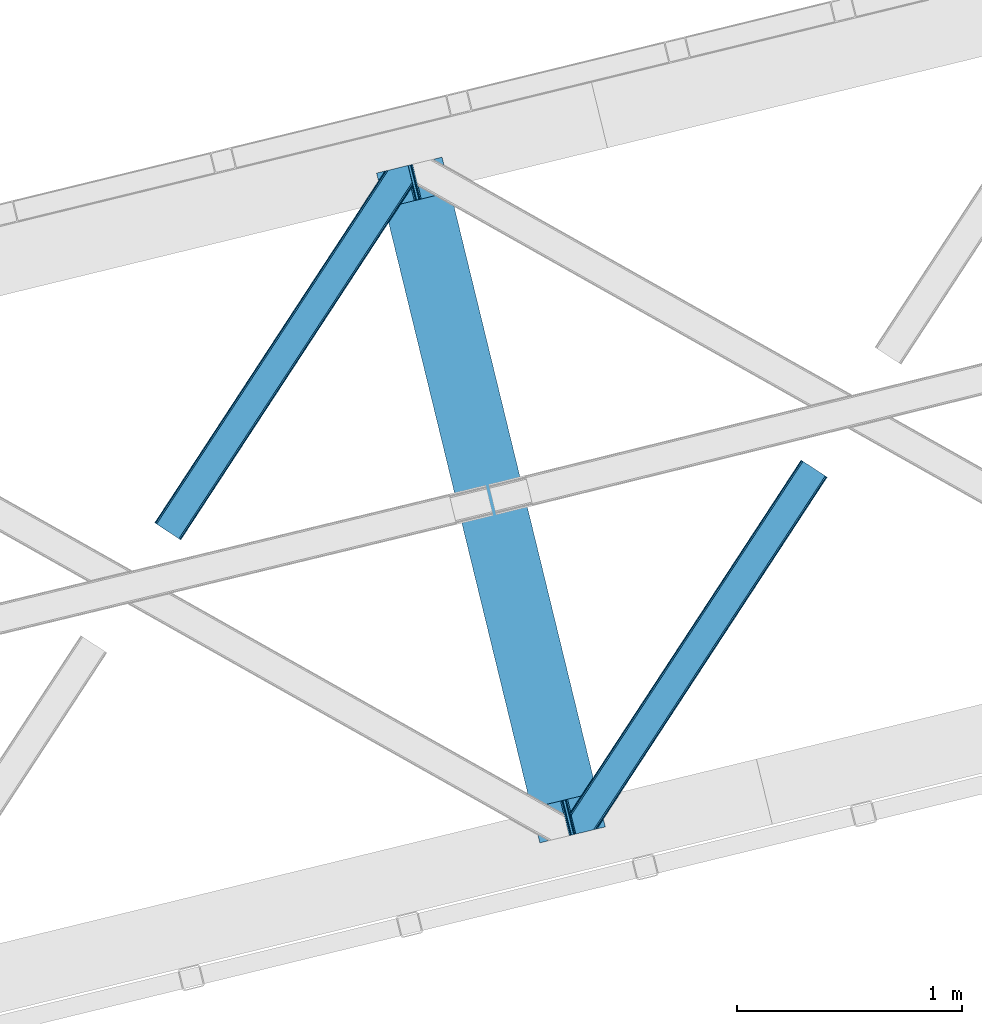
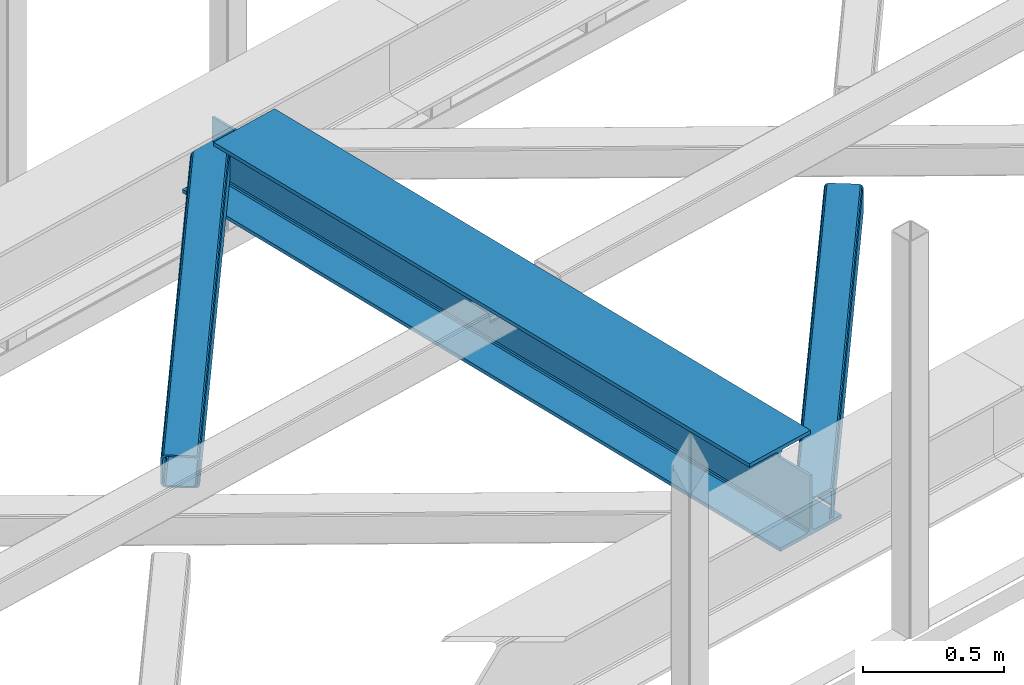
# One storey, part 29 of 66: 2 members, 1 beam.
"""IFC4 building model written with IfcOpenShell, lengths in millimetres."""

from ifc_helpers import new_model, entity, si_unit, converted_unit, derived_unit, direction, frame, origin, place, context, subcontext, project, spatial, triangles, polygons, material, type_object, element, save


model = new_model("IFC4")

# Units and contexts
model_context = context("Model", 3, precision=0.01, world=origin(), true_north=direction((6.12303176911189e-17, 1.0)))
plan_context = context("Plan", 3, precision=0.01, world=origin(), true_north=direction((6.12303176911189e-17, 1.0)))
body_context = subcontext(model_context, "Body", "Model", "MODEL_VIEW")
ifc_project = project(units=[si_unit("LENGTHUNIT", "METRE", prefix="MILLI"), si_unit("AREAUNIT", "SQUARE_METRE"), si_unit("VOLUMEUNIT", "CUBIC_METRE"), converted_unit("PLANEANGLEUNIT", "DEGREE", entity("IfcRatioMeasure", 0.0174532925199433), si_unit("PLANEANGLEUNIT", "RADIAN"), dimensions=[0, 0, 0, 0, 0, 0, 0]), si_unit("MASSUNIT", "GRAM", prefix="KILO"), derived_unit("MASSDENSITYUNIT", [(si_unit("MASSUNIT", "GRAM", prefix="KILO"), 1), (si_unit("LENGTHUNIT", "METRE"), -3)]), derived_unit("MOMENTOFINERTIAUNIT", [(si_unit("LENGTHUNIT", "METRE"), 4)]), si_unit("TIMEUNIT", "SECOND"), si_unit("FREQUENCYUNIT", "HERTZ"), si_unit("THERMODYNAMICTEMPERATUREUNIT", "DEGREE_CELSIUS"), derived_unit("THERMALTRANSMITTANCEUNIT", [(si_unit("MASSUNIT", "GRAM", prefix="KILO"), 1), (si_unit("THERMODYNAMICTEMPERATUREUNIT", "KELVIN"), -1), (si_unit("TIMEUNIT", "SECOND"), -3)]), derived_unit("VOLUMETRICFLOWRATEUNIT", [(si_unit("LENGTHUNIT", "METRE"), 3), (si_unit("TIMEUNIT", "SECOND"), -1)]), derived_unit("MASSFLOWRATEUNIT", [(si_unit("MASSUNIT", "GRAM", prefix="KILO"), 1), (si_unit("TIMEUNIT", "SECOND"), -1)]), derived_unit("ROTATIONALFREQUENCYUNIT", [(si_unit("TIMEUNIT", "SECOND"), -1)]), si_unit("ELECTRICCURRENTUNIT", "AMPERE"), si_unit("ELECTRICVOLTAGEUNIT", "VOLT"), si_unit("POWERUNIT", "WATT"), si_unit("FORCEUNIT", "NEWTON", prefix="KILO"), si_unit("ILLUMINANCEUNIT", "LUX"), si_unit("LUMINOUSFLUXUNIT", "LUMEN"), si_unit("LUMINOUSINTENSITYUNIT", "CANDELA"), derived_unit("USERDEFINED", [(si_unit("MASSUNIT", "GRAM", prefix="KILO"), -1), (si_unit("LENGTHUNIT", "METRE"), -2), (si_unit("TIMEUNIT", "SECOND"), 3), (si_unit("LUMINOUSFLUXUNIT", "LUMEN"), 1)]), derived_unit("LINEARVELOCITYUNIT", [(si_unit("LENGTHUNIT", "METRE"), 1), (si_unit("TIMEUNIT", "SECOND"), -1)]), si_unit("PRESSUREUNIT", "PASCAL"), derived_unit("USERDEFINED", [(si_unit("LENGTHUNIT", "METRE"), -2), (si_unit("MASSUNIT", "GRAM", prefix="KILO"), 1), (si_unit("TIMEUNIT", "SECOND"), -2)]), derived_unit("LINEARFORCEUNIT", [(si_unit("MASSUNIT", "GRAM", prefix="KILO"), 1), (si_unit("LENGTHUNIT", "METRE"), 1), (si_unit("TIMEUNIT", "SECOND"), -2), (si_unit("LENGTHUNIT", "METRE"), -1)]), derived_unit("PLANARFORCEUNIT", [(si_unit("MASSUNIT", "GRAM", prefix="KILO"), 1), (si_unit("LENGTHUNIT", "METRE"), 1), (si_unit("TIMEUNIT", "SECOND"), -2), (si_unit("LENGTHUNIT", "METRE"), -2)])], contexts=[model_context, plan_context])

# Site, building, storey
site_placement = place(None, origin())
site = spatial("IfcSite", under=ifc_project, at=site_placement, CompositionType="ELEMENT")
building_placement = place(site_placement, origin())
building = spatial("IfcBuilding", under=site, at=building_placement, CompositionType="ELEMENT")
storey_placement = place(building_placement, frame((0.0, 0.0, 19800.0)))
storey = spatial("IfcBuildingStorey", under=building, at=storey_placement, Name="06", CompositionType="ELEMENT", Elevation=19800.0)

# Beam
ifc_material = material(Name="Metal painted (White)")
beam_type = type_object("IfcBeamType", PredefinedType="BEAM")
beam_placement = place(storey_placement, frame((-43080.93, 7293.5, 3808.0)))
element("IfcBeam", 1, at=beam_placement, inside=storey, type_object=beam_type, material=ifc_material, ObjectType="Steel Beam", PredefinedType="BEAM", context=body_context, shape_type="Tessellation", body=[
    polygons([(1018.1664837833, 71.047827897101, 15.5000000000051), (1018.1664837833, 71.0478278971021, 0.0), (291.465617442446, 3052.25531830421, 0.0), (291.465617442455, 3052.25531830421, 15.5000000000051), (894.779372399338, 40.9709140873291, 15.5000000000051), (168.078506058482, 3022.17840449444, 15.5000000000051), (888.087028625366, 39.3395844888243, 16.8701684148028), (161.38616228452, 3020.54707489594, 16.8701684148028), (882.413533524751, 37.956610033653, 20.7720779386478), (155.712667183904, 3019.16410044076, 20.7720779386478), (878.622625296176, 37.0325360459184, 26.6116982174338), (151.921758955329, 3018.24002645303, 26.6116982174338), (877.291435352788, 36.7080444135018, 33.500000000001), (150.590569011924, 3017.91553482062, 33.500000000001), (140.875048430514, 3015.54727389071, 33.500000000001), (140.875048430522, 3015.54727389071, 259.000000000006), (150.590569011924, 3017.91553482061, 259.000000000006), (0.0, 2981.20749040711, 4.33146851719357e-12), (0.0, 2981.20749040711, 15.5000000000051), (123.387111383972, 3011.28440421688, 15.5000000000051), (130.079455157918, 3012.91573381539, 16.8701684148028), (135.752950258542, 3014.29870827056, 20.7720779386478), (139.543858487117, 3015.2227822583, 26.6116982174338), (877.291435352779, 36.7080444135018, 259.000000000006), (867.575914771369, 34.3397834835981, 259.000000000006), (867.575914771369, 34.3397834835981, 33.500000000001), (866.244724827972, 34.0152918511837, 26.6116982174338), (862.453816599406, 33.0912178634492, 20.7720779386478), (856.780321498782, 31.7082434082778, 16.8701684148028), (850.087977724819, 30.076913809773, 15.5000000000051), (726.700866340864, 0.0, 15.5000000000051), (726.700866340864, 0.0, 4.33146851719357e-12), (839.723099725414, 190.827961666225, 259.069792599954), (188.068298227647, 2864.16742161973, 259.000000000006), (188.291691329497, 2863.25097721476, 259.617303331129), (188.304080173122, 2863.20015298098, 266.500003008253), (839.577920935824, 191.42343960925, 266.500002998871), (839.578271056576, 191.422003304514, 260.000004007593), (830.098162489501, 188.087889491627, 259.00634317046), (829.874792453805, 189.004341089457, 259.617303331129), (829.862403610162, 189.055165323231, 266.500003008253), (178.588562847469, 2860.83187869496, 266.500002998871), (178.588212726717, 2860.8333149997, 260.000004007593), (178.443407068381, 2861.42736381349, 259.076120467494), (178.352777646246, 2861.79916068982, 259.000000000006), (840.90940880576, 191.746709053936, 273.388305639792), (844.699685394447, 192.673374225849, 279.227924098781), (850.372756341985, 194.058088689525, 283.129832400619), (857.06494802311, 195.690042220338, 284.500000377228), (980.451976710954, 225.76729527545, 284.500000138975), (980.450306904303, 225.774145344181, 299.999995328161), (688.984884807032, 154.725516080139, 299.999995890966), (688.986554613693, 154.718666011408, 284.500000701776), (812.373583301528, 184.795919066518, 284.500000463524), (819.066070197675, 186.426661533098, 283.129832461069), (824.739981846427, 187.807927177623, 279.227924137327), (828.531516633419, 188.72943082692, 273.388305663689), (177.257074977551, 2860.50860925028, 273.388305639792), (173.466798388846, 2859.58194407836, 279.227924098781), (167.793727441316, 2858.19722961469, 283.129832400619), (161.101535760182, 2856.56527608387, 284.500000377228), (37.7145070723471, 2826.48802302876, 284.500000138975), (37.7161768789988, 2826.48117296003, 299.999995328161), (329.181598976269, 2897.52980222407, 299.999995890962), (329.179929169617, 2897.5366522928, 284.500000701776), (205.792900481765, 2867.45939923769, 284.500000463524), (199.100413585626, 2865.82865677111, 283.129832461069), (193.426501936866, 2864.44739112659, 279.227924137327), (189.634967149874, 2863.52588747729, 273.388305663689)], [[[1, 2, 3, 4]], [[5, 1, 4, 6]], [[7, 5, 6, 8]], [[9, 7, 8, 10]], [[11, 9, 10, 12]], [[13, 11, 12, 14]], [[15, 16, 17, 14, 12, 10, 8, 6, 4, 3, 18, 19, 20, 21, 22, 23]], [[13, 24, 25, 26, 27, 28, 29, 30, 31, 32, 2, 1, 5, 7, 9, 11]], [[2, 32, 18, 3]], [[32, 31, 19, 18]], [[31, 30, 20, 19]], [[27, 26, 15, 23]], [[28, 27, 23, 22]], [[29, 28, 22, 21]], [[30, 29, 21, 20]], [[33, 24, 13, 14, 17, 34, 35, 36, 37, 38]], [[25, 39, 40, 41, 42, 43, 44, 16, 15, 26]], [[39, 25, 24, 33]], [[45, 34, 17, 16]], [[41, 40, 38, 37, 46, 47, 48, 49, 50, 51, 52, 53, 54, 55, 56, 57]], [[42, 58, 59, 60, 61, 62, 63, 64, 65, 66, 67, 68, 69, 36, 35, 43]], [[46, 37, 36, 69]], [[47, 46, 69, 68]], [[48, 47, 68, 67]], [[49, 48, 67, 66]], [[50, 49, 66, 65]], [[51, 50, 65, 64]], [[52, 51, 64, 63]], [[53, 52, 63, 62]], [[54, 53, 62, 61]], [[55, 54, 61, 60]], [[56, 55, 60, 59]], [[57, 56, 59, 58]], [[41, 57, 58, 42]]], closed=False),
])

# Members
member_type_1 = type_object("IfcMemberType", PredefinedType="BRACE")
member_1_placement = place(storey_placement, frame((-44069.14, 8641.5, 3824.0)))
element("IfcMember", 2, at=member_1_placement, inside=storey, type_object=member_type_1, ObjectType="Steel Horizontal Brace", PredefinedType="BRACE", context=body_context, shape_type="Tessellation", body=[
    triangles([(994.771838378911, 1564.02662658691, 0.0), (1028.82092285156, 1424.34794311523, 0.0), (14.6409667968765, 67.1040435791019, 0.0), (102.486767578128, 9.58604278564417, 0.0), (1.1162109375, 75.9604797363281, 10.8039916992202), (0.0, 76.6900863647461, 17.5012573242202), (1025.02580566407, 1642.17883300781, 17.5012573242202), (4.28811035156832, 73.8821182250977, 5.12526855468968), (990.474426269531, 1585.8776184082, 9.49942016601563), (990.041894531256, 1584.44747314453, 8.74132690429906), (989.90701904297, 1583.99168701172, 8.49948120117188), (990.758129882815, 1580.48841247559, 5.12526855468968), (1027.30938720703, 1642.73461303711, 10.8691040039084), (1027.77912597657, 1642.84972229004, 9.49942016601563), (992.599877929693, 1572.93538513184, 1.33247680664135), (9.03665771484521, 70.7724243164066, 1.33247680664135), (1025.02580566407, 1642.17883300781, 122.499499511719), (0.0, 76.6900863647461, 122.499499511719), (1026.92336425782, 1642.64043273926, 129.196765136719), (1.1162109375, 75.9604797363281, 129.196765136719), (1032.31838378907, 1643.95546875, 134.87548828125), (4.28811035156832, 73.8821182250977, 134.87548828125), (1040.39230957031, 1645.92395324707, 138.668280029298), (9.03665771484521, 70.7724243164066, 138.668280029298), (1049.91730957032, 1648.24590454102, 140.00075683594), (14.6409667968765, 67.1040435791019, 140.00075683594), (994.869506835938, 1567.85081176758, 9.49942016601563), (994.75788574219, 1567.00667724609, 9.2947814941399), (994.650915527345, 1566.15091552734, 9.08781738281323), (994.539294433598, 1565.30561828613, 8.8831787109375), (994.74393310547, 1564.14522399902, 8.49948120117188), (1047.05236816406, 1647.54827270508, 9.49942016601563), (14.8921142578183, 66.9377746582031, 8.3320495605476), (20.4964233398496, 63.2693939208984, 6.99957275390625), (997.041467285162, 1554.71440429688, 6.99957275390625), (10.1435668945342, 70.0480499267578, 12.1248413085959), (1042.27126464844, 1646.38322753906, 12.1248413085959), (1036.87624511719, 1645.06702880859, 17.8035644531265), (1034.98333740234, 1644.60542907715, 24.5008300781265), (6.97166748047312, 72.1258300781246, 17.8035644531265), (5.85545654297312, 72.8554367065426, 24.5008300781265), (1026.55129394532, 1433.65900268555, 6.99957275390625), (96.6266601562529, 13.4206924438477, 6.99957275390625), (1028.71860351563, 1424.77698669434, 8.41343994140698), (1032.83463134766, 1407.88615722656, 5.12526855468968), (1033.6857421875, 1404.3817199707, 8.49948120117188), (1030.99288330079, 1415.43918457031, 1.33247680664135), (1034.98333740234, 1644.60542907715, 115.499926757813), (5.85545654297312, 72.8554367065426, 115.499926757813), (1050.3498413086, 1648.35171203613, 131.668707275392), (1059.8748413086, 1650.67250061035, 133.001184082033), (20.4964233398496, 63.2693939208984, 133.001184082033), (14.8921142578183, 66.9377746582031, 131.668707275392), (1042.27126464844, 1646.38322753906, 127.873590087893), (10.1435668945342, 70.0480499267578, 127.873590087893), (1036.87624511719, 1645.06702880859, 122.197192382813), (6.97166748047312, 72.1258300781246, 122.197192382813), (1128.10788574219, 1667.30520629883, 140.00075683594), (1128.10788574219, 1667.30520629883, 133.001184082033), (1144.33015136719, 1600.75810546875, 140.00075683594), (102.486767578128, 9.58604278564417, 140.00075683594), (1142.06052246094, 1610.07032775879, 133.001184082033), (96.6266601562529, 13.4206924438477, 133.001184082033), (1146.50211181641, 1591.84934692383, 138.668280029298), (108.08642578125, 5.91766204833948, 138.668280029298), (1148.33920898438, 1584.29631958008, 134.87548828125), (112.834973144534, 2.80738677978479, 134.87548828125), (1149.57169189453, 1579.2501159668, 129.196765136719), (116.011523437504, 0.729606628417969, 129.196765136719), (1150.00422363282, 1577.47813110351, 122.499499511719), (117.127734375004, 0.0, 122.499499511719), (1150.00422363282, 1577.47813110351, 17.5012573242202), (117.127734375004, 0.0, 17.5012573242202), (106.979516601568, 6.64203643798828, 127.873590087893), (110.156066894531, 4.56425628662146, 122.197192382813), (111.267626953129, 3.83406829833984, 115.499926757813), (102.230969238284, 9.75231170654297, 131.668707275392), (116.011523437504, 0.729606628417969, 10.8039916992202), (106.979516601568, 6.64203643798828, 12.1248413085959), (112.834973144534, 2.80738677978479, 5.12526855468968), (111.267626953129, 3.83406829833984, 24.5008300781265), (110.156066894531, 4.56425628662146, 17.8035644531265), (108.08642578125, 5.91766204833948, 1.33247680664135), (102.230969238284, 9.75231170654297, 8.3320495605476), (1147.30206298828, 1588.56233825684, 122.197192382813), (1147.73459472656, 1586.79035339356, 115.499926757813), (1146.06958007813, 1593.60854187012, 127.873590087893), (1144.23248291016, 1601.16040649414, 131.668707275392), (1147.73459472656, 1586.79035339356, 24.5008300781265), (1147.21369628907, 1588.9239440918, 17.8686767578147), (1149.994921875, 1577.51650085449, 16.5013183593765), (1147.10672607422, 1589.36461486816, 16.5013183593765), (1145.27427978516, 1573.10863037109, 10.8714294433594), (1034.62056884766, 1404.788671875, 9.49942016601563), (1144.12551269532, 1572.03427734375, 9.49942016601563), (1142.79071044922, 1588.59721984863, 12.1248413085959), (1030.22548828126, 1422.8143157959, 9.49942016601563), (1029.19764404297, 1423.6724029541, 8.80643920898365), (1139.73043212891, 1590.05992126465, 9.49942016601563)], [[1, 2, 3], [4, 3, 2], [5, 6, 7], [8, 9, 10], [11, 12, 8], [5, 13, 9], [9, 8, 5], [13, 14, 9], [15, 1, 16], [3, 16, 1], [12, 15, 8], [16, 8, 15], [7, 13, 5], [17, 7, 6], [6, 18, 17], [19, 17, 20], [18, 20, 17], [21, 19, 22], [20, 22, 19], [23, 21, 24], [22, 24, 21], [25, 23, 26], [24, 26, 23], [27, 28, 9], [28, 29, 10], [29, 30, 10], [30, 31, 11], [14, 32, 27], [27, 9, 14], [33, 34, 35], [36, 33, 31], [31, 30, 36], [28, 36, 29], [28, 27, 36], [36, 30, 29], [32, 37, 27], [36, 27, 37], [35, 31, 33], [38, 39, 40], [41, 40, 39], [37, 38, 36], [40, 36, 38], [42, 35, 34], [34, 43, 42], [1, 35, 42], [31, 12, 11], [1, 31, 35], [31, 15, 12], [31, 1, 15], [2, 1, 42], [44, 2, 42], [45, 44, 46], [44, 47, 2], [44, 45, 47], [39, 48, 41], [49, 41, 48], [50, 51, 52], [52, 53, 50], [54, 50, 53], [53, 55, 54], [56, 54, 55], [55, 57, 56], [48, 56, 57], [57, 49, 48], [56, 17, 19], [50, 23, 25], [58, 51, 25], [51, 58, 59], [51, 50, 25], [54, 23, 50], [54, 56, 21], [21, 23, 54], [19, 21, 56], [39, 7, 17], [37, 14, 38], [56, 48, 17], [37, 32, 14], [39, 38, 7], [48, 39, 17], [13, 7, 38], [38, 14, 13], [60, 25, 61], [25, 60, 58], [26, 61, 25], [51, 62, 63], [51, 59, 62], [63, 52, 51], [64, 60, 61], [61, 65, 64], [66, 64, 65], [65, 67, 66], [68, 66, 67], [67, 69, 68], [70, 68, 69], [69, 71, 70], [72, 70, 71], [71, 73, 72], [69, 74, 75], [76, 73, 71], [69, 75, 71], [69, 67, 74], [75, 76, 71], [74, 67, 65], [63, 61, 26], [61, 77, 65], [77, 61, 63], [77, 74, 65], [78, 79, 80], [81, 73, 76], [73, 82, 78], [82, 73, 81], [78, 82, 79], [4, 43, 3], [83, 80, 79], [79, 84, 83], [84, 43, 4], [4, 83, 84], [55, 24, 22], [26, 52, 63], [26, 53, 52], [53, 26, 24], [55, 53, 24], [49, 18, 6], [20, 57, 55], [22, 20, 55], [57, 20, 18], [49, 57, 18], [16, 36, 8], [3, 43, 34], [34, 33, 3], [33, 36, 16], [16, 3, 33], [5, 8, 36], [6, 41, 49], [40, 6, 5], [6, 40, 41], [40, 5, 36], [85, 86, 75], [76, 75, 86], [87, 85, 74], [75, 74, 85], [88, 87, 77], [74, 77, 87], [62, 88, 63], [77, 63, 88], [86, 89, 76], [81, 76, 89], [90, 91, 92], [70, 72, 89], [72, 90, 89], [89, 86, 70], [72, 91, 90], [85, 70, 86], [68, 70, 85], [66, 85, 87], [85, 66, 68], [87, 64, 66], [88, 64, 87], [88, 62, 60], [88, 60, 64], [62, 58, 60], [62, 59, 58], [73, 78, 93], [93, 72, 73], [94, 93, 78], [94, 95, 93], [80, 45, 46], [46, 78, 80], [46, 94, 78], [47, 45, 83], [80, 83, 45], [2, 47, 4], [83, 4, 47], [93, 91, 72], [82, 81, 89], [82, 92, 96], [82, 90, 92], [84, 97, 98], [79, 96, 97], [97, 84, 79], [96, 99, 97], [43, 84, 44], [44, 42, 43], [96, 79, 82], [89, 90, 82], [96, 91, 93], [96, 92, 91], [96, 95, 99], [93, 95, 96], [99, 95, 97], [94, 97, 95]]),
])
member_type_2 = type_object("IfcMemberType", PredefinedType="BRACE")
member_2_placement = place(storey_placement, frame((-42217.82, 7332.57, 3824.0)))
element("IfcMember", 3, at=member_2_placement, inside=storey, type_object=member_type_2, ObjectType="Steel Horizontal Brace", PredefinedType="BRACE", context=body_context, shape_type="Tessellation", body=[
    triangles([(109.770043945311, 259.950411987305, 7.52047119140843), (115.034838867192, 238.366264343262, 7.77626953125218), (114.220935058598, 239.947563171387, 8.3320495605476), (108.811962890628, 259.663220214844, 8.52041015625218), (113.639575195317, 239.860359191895, 8.52041015625218), (112.211755371092, 237.678515625, 8.52041015625218), (91.0363037109419, 232.517202758789, 8.52041015625218), (109.537499999999, 237.026229858398, 9.49942016601563), (90.2642578125015, 232.328842163086, 9.49942016601563), (5.02294921875, 77.405158996582, 9.49942016601563), (0.62786865234375, 95.4313842773436, 9.49942016601563), (1046.62448730469, 1651.75382995605, 6.99957275390625), (1041.02482910157, 1655.42279205322, 8.3320495605476), (116.704504394533, 231.514938354492, 6.99957275390625), (1036.27163085937, 1658.53248596191, 12.1248413085959), (3.93464355469041, 81.8758163452148, 12.1248413085959), (1033.09973144531, 1660.61084747314, 17.8035644531265), (2.70216064453416, 86.9220199584961, 17.8035644531265), (1031.98352050781, 1661.3398727417, 24.5008300781265), (2.26962890625146, 88.6945861816403, 24.5008300781265), (1122.759375, 1601.905128479, 6.99957275390625), (146.20968017578, 110.459536743164, 6.99957275390625), (1031.98352050781, 1661.3398727417, 115.499926757813), (2.26962890625146, 88.6945861816403, 115.499926757813), (1033.09973144531, 1660.61084747314, 122.197192382813), (2.70216064453416, 86.9220199584961, 122.197192382813), (1036.27163085937, 1658.53248596191, 127.873590087893), (3.93464355469041, 81.8758163452148, 127.873590087893), (1041.02482910157, 1655.42279205322, 131.668707275392), (5.77174072265916, 74.3233703613278, 131.668707275392), (1046.62448730469, 1651.75382995605, 133.001184082033), (7.94370117187646, 65.4146118164063, 133.001184082033), (1027.24427490235, 1664.44491577148, 10.8039916992202), (0.520898437498545, 95.8720550537109, 10.8691040039084), (0.0, 98.0062271118168, 17.5012573242202), (1035.16472167969, 1659.25686035156, 1.33247680664135), (112.262915039064, 249.735919189453, 1.33247680664135), (110.546740722661, 256.77269897461, 5.59500732422021), (109.077062988283, 259.839953613281, 8.32042236328198), (1030.41617431641, 1662.36713562012, 5.12526855468968), (1040.76903076172, 1655.58847961426, 0.0), (114.434875488281, 240.827160644531, 0.0), (1026.12806396485, 1665.1745223999, 17.5012573242202), (1128.61483154297, 1598.07106018066, 0.0), (148.479309082031, 101.147895812988, 0.0), (150.651269531249, 92.2391372680668, 1.33247680664135), (148.511865234374, 101.029879760742, 8.49948120117188), (152.493017578126, 84.6866912841797, 5.12526855468968), (153.348779296874, 81.1828353881838, 8.49948120117188), (1026.12806396485, 1665.1745223999, 122.499499511719), (0.0, 98.0062271118168, 122.499499511719), (1040.76903076172, 1655.58847961426, 140.00075683594), (1035.16472167969, 1659.25686035156, 138.668280029298), (3.50211181640771, 83.6350112915043, 138.668280029298), (5.674072265625, 74.7262527465818, 140.00075683594), (1030.41617431641, 1662.36713562012, 134.87548828125), (1.66501464843896, 91.1874572753904, 134.87548828125), (1027.24427490235, 1664.44491577148, 129.196765136719), (0.432531738282705, 96.2342422485353, 129.196765136719), (23.8915649414048, 0.0, 140.00075683594), (23.8915649414048, 0.0, 133.001184082033), (1128.61483154297, 1598.07106018066, 140.00075683594), (93.3384887695356, 16.9286178588864, 140.00075683594), (1122.759375, 1601.905128479, 133.001184082033), (83.3809570312515, 14.5014404296871, 133.001184082033), (1143.25579833984, 1588.48443603516, 122.499499511719), (1142.13958740234, 1589.21404266357, 129.196765136719), (118.225341796875, 22.9956893920898, 122.499499511719), (116.332434082033, 22.5340896606449, 129.196765136719), (1138.96768798828, 1591.2924041748, 134.87548828125), (110.937414550783, 21.219053649902, 134.87548828125), (1134.2144897461, 1594.4020980835, 138.668280029298), (102.86348876953, 19.2505691528322, 138.668280029298), (1143.25579833984, 1588.48443603516, 17.5012573242202), (118.225341796875, 22.9956893920898, 17.5012573242202), (1142.13958740234, 1589.21404266357, 10.8039916992202), (1133.11223144532, 1595.12705383301, 12.1248413085959), (1136.28413085938, 1593.04869232178, 17.8035644531265), (1137.40034179688, 1592.31908569336, 24.5008300781265), (1138.96768798828, 1591.2924041748, 5.12526855468968), (1134.2144897461, 1594.4020980835, 1.33247680664135), (1128.35903320312, 1598.2367477417, 8.3320495605476), (1133.11223144532, 1595.12705383301, 127.873590087893), (1137.40034179688, 1592.31908569336, 115.499926757813), (1136.28413085938, 1593.04869232178, 122.197192382813), (1128.35903320312, 1598.2367477417, 131.668707275392), (92.9059570312529, 16.823391723633, 131.668707275392), (100.979882812499, 18.7918762207028, 127.873590087893), (106.374902343749, 20.1069122314457, 122.197192382813), (108.2724609375, 20.5690933227543, 115.499926757813), (108.2724609375, 20.5690933227543, 24.5008300781265), (100.979882812499, 18.7918762207028, 12.1248413085959), (115.472021484376, 22.3248001098636, 9.49942016601563), (106.374902343749, 20.1069122314457, 17.8035644531265), (96.2034301757813, 17.6268310546875, 9.49942016601563), (115.946411132813, 22.4393280029299, 10.8691040039084), (153.065075683597, 80.2398696899418, 8.99945068359375), (152.776721191411, 79.2974853515625, 9.49942016601563), (148.711853027344, 99.8683227539059, 8.8831787109375), (148.604882812499, 99.0241882324217, 9.08781738281323), (148.493261718751, 98.1678451538082, 9.2947814941399), (148.386291503906, 97.3231292724613, 9.49942016601563)], [[1, 2, 3], [4, 5, 6], [6, 7, 4], [7, 6, 8], [8, 9, 7], [9, 8, 10], [10, 11, 9], [12, 13, 3], [3, 2, 12], [2, 14, 12], [15, 16, 8], [8, 13, 15], [8, 5, 13], [16, 10, 8], [8, 6, 5], [15, 17, 18], [18, 16, 15], [17, 19, 20], [20, 18, 17], [21, 12, 14], [14, 22, 21], [19, 23, 24], [24, 20, 19], [23, 25, 24], [26, 24, 25], [25, 27, 26], [28, 26, 27], [27, 29, 28], [30, 28, 29], [29, 31, 30], [32, 30, 31], [33, 34, 35], [36, 37, 38], [33, 4, 9], [33, 1, 39], [9, 34, 33], [9, 11, 34], [4, 7, 9], [40, 38, 1], [1, 33, 40], [38, 40, 36], [36, 41, 37], [42, 37, 41], [35, 43, 33], [41, 44, 42], [45, 42, 44], [14, 42, 22], [37, 2, 38], [2, 37, 42], [38, 2, 1], [42, 14, 2], [22, 42, 45], [46, 47, 45], [47, 46, 48], [45, 47, 22], [48, 49, 47], [50, 43, 35], [35, 51, 50], [52, 53, 54], [54, 55, 52], [53, 56, 57], [57, 54, 53], [56, 58, 59], [59, 57, 56], [58, 50, 51], [51, 59, 58], [28, 57, 26], [30, 32, 55], [32, 60, 55], [32, 61, 60], [54, 30, 55], [28, 54, 57], [16, 11, 10], [28, 30, 54], [51, 35, 20], [24, 26, 51], [24, 51, 20], [57, 59, 26], [26, 59, 51], [35, 18, 20], [18, 11, 16], [11, 18, 34], [35, 34, 18], [62, 55, 63], [62, 52, 55], [55, 60, 63], [64, 32, 31], [32, 64, 65], [61, 32, 65], [66, 67, 68], [69, 68, 67], [67, 70, 69], [71, 69, 70], [70, 72, 71], [73, 71, 72], [72, 62, 73], [63, 73, 62], [74, 66, 68], [68, 75, 74], [76, 77, 78], [79, 66, 74], [76, 78, 74], [76, 80, 77], [78, 79, 74], [77, 80, 81], [21, 44, 41], [44, 82, 81], [82, 44, 21], [82, 77, 81], [67, 83, 70], [84, 66, 79], [66, 85, 67], [85, 66, 84], [67, 85, 83], [62, 64, 52], [72, 70, 83], [83, 86, 72], [86, 64, 62], [62, 72, 86], [15, 36, 40], [41, 12, 21], [41, 13, 12], [13, 41, 36], [15, 13, 36], [19, 43, 50], [33, 17, 15], [40, 33, 15], [17, 33, 43], [19, 17, 43], [53, 27, 56], [52, 64, 31], [31, 29, 52], [29, 27, 53], [53, 52, 29], [58, 56, 27], [50, 23, 19], [25, 50, 58], [50, 25, 23], [25, 58, 27], [64, 86, 87], [87, 65, 64], [86, 83, 88], [88, 87, 86], [83, 85, 89], [89, 88, 83], [85, 84, 90], [90, 89, 85], [84, 79, 91], [91, 90, 84], [89, 68, 69], [87, 73, 63], [60, 65, 63], [65, 60, 61], [65, 87, 63], [88, 73, 87], [88, 89, 71], [71, 73, 88], [69, 71, 89], [91, 75, 68], [92, 93, 94], [89, 90, 68], [92, 95, 93], [91, 94, 75], [90, 91, 68], [96, 75, 94], [94, 93, 96], [76, 74, 75], [49, 80, 97], [98, 97, 80], [49, 48, 80], [76, 96, 98], [98, 80, 76], [96, 93, 98], [44, 81, 45], [46, 45, 81], [81, 80, 46], [48, 46, 80], [75, 96, 76], [82, 21, 22], [77, 82, 47], [47, 99, 77], [77, 100, 101], [100, 77, 99], [101, 102, 77], [77, 102, 92], [95, 92, 102], [22, 47, 82], [79, 78, 91], [94, 91, 78], [78, 77, 94], [92, 94, 77], [102, 101, 98], [101, 100, 97], [100, 99, 49], [99, 47, 49], [102, 98, 93], [93, 95, 102]]),
])

save(model, "model.ifc")
